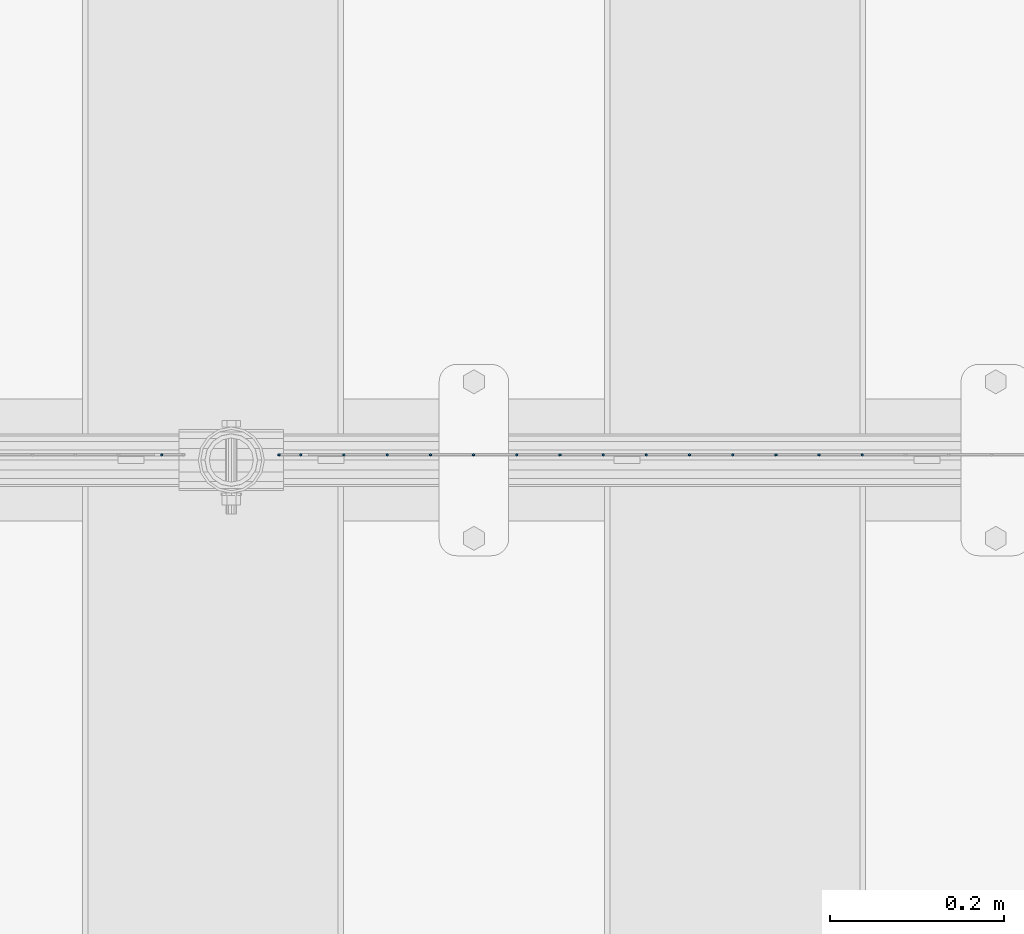
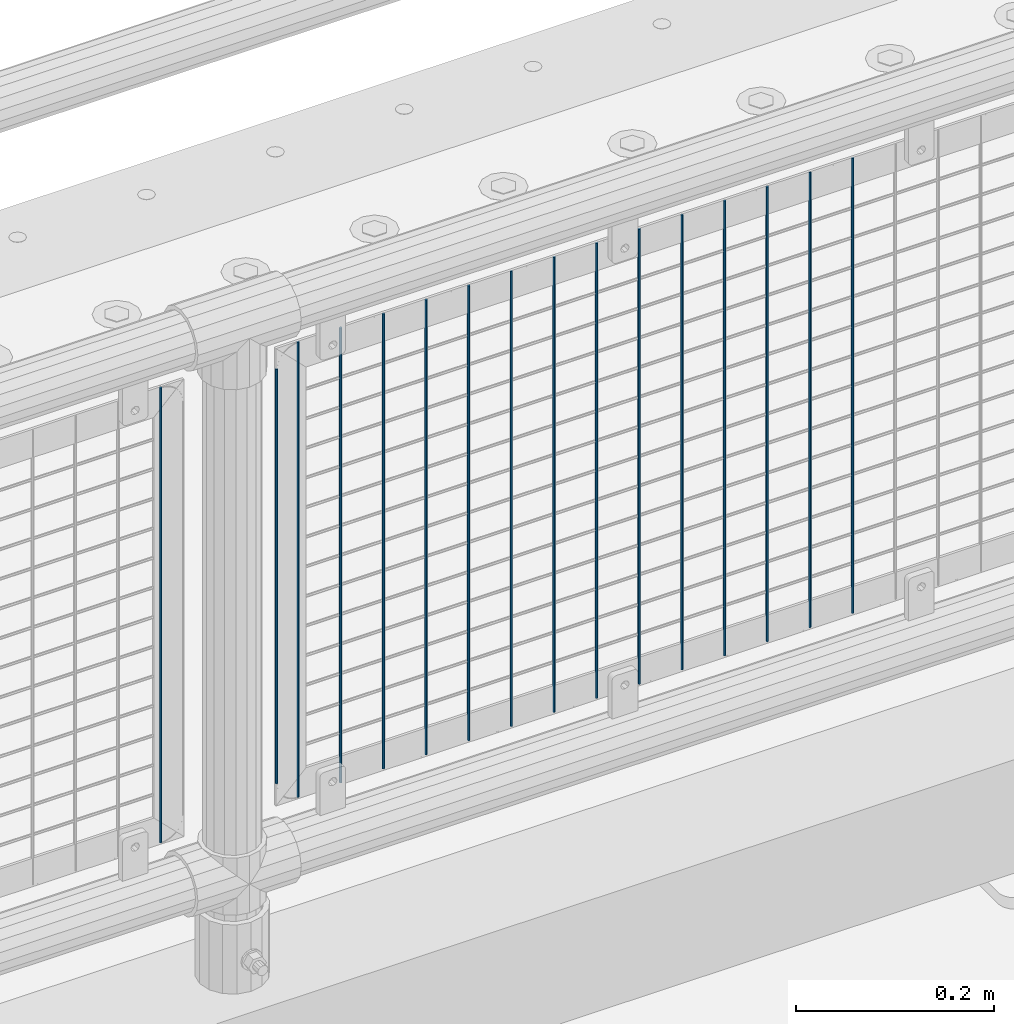
# One storey, part 72 of 247: 16 columns.
"""IFC2X3 building model written with IfcOpenShell, lengths in millimetres."""

from ifc_helpers import new_model, si_unit, frame, origin_with_axes, place, context, subcontext, project, spatial, faceted_brep, material, type_object, element, save


model = new_model("IFC2X3")

# Units and contexts
model_context = context("Model", 3, precision=1e-05, world=origin_with_axes())
body_context = subcontext(model_context, "Body", "Model", "MODEL_VIEW")
ifc_project = project(units=[si_unit("LENGTHUNIT", "METRE", prefix="MILLI"), si_unit("AREAUNIT", "SQUARE_METRE"), si_unit("VOLUMEUNIT", "CUBIC_METRE"), si_unit("MASSUNIT", "GRAM", prefix="KILO"), si_unit("TIMEUNIT", "SECOND"), si_unit("PLANEANGLEUNIT", "RADIAN"), si_unit("SOLIDANGLEUNIT", "STERADIAN"), si_unit("THERMODYNAMICTEMPERATUREUNIT", "DEGREE_CELSIUS"), si_unit("LUMINOUSINTENSITYUNIT", "LUMEN")], contexts=[model_context])

# Site, building, storey
site_placement = place(None, origin_with_axes())
site = spatial("IfcSite", under=ifc_project, at=site_placement, CompositionType="ELEMENT")
building_placement = place(site_placement, origin_with_axes())
building = spatial("IfcBuilding", under=site, at=building_placement, Name="Standard", CompositionType="ELEMENT")
storey_placement = place(building_placement, origin_with_axes())
storey = spatial("IfcBuildingStorey", under=building, at=storey_placement, Name="Undefined", CompositionType="ELEMENT", Elevation=0.0)

# Columns
ifc_material = material(Name="Misc_Undefined")
column_type = type_object("IfcColumnType", Name="D3", PredefinedType="NOTDEFINED")
for number, where, z_axis, x_axis in (
    (1, (2946.515, 7670.5, 353.02), (-1.0, 0.0, 0.0), (0.0, 0.0, 1.0)),
    (2, (2896.86, 7670.5, 353.02), (-1.0, 0.0, 0.0), (0.0, 0.0, 1.0)),
    (3, (2847.205, 7670.5, 353.02), (-1.0, 0.0, 0.0), (0.0, 0.0, 1.0)),
    (4, (2797.55, 7670.5, 353.02), (-1.0, 0.0, 0.0), (0.0, 0.0, 1.0)),
    (5, (2747.895, 7670.5, 353.02), (-1.0, 0.0, 0.0), (0.0, 0.0, 1.0)),
    (6, (2698.24, 7670.5, 353.02), (-1.0, 0.0, 0.0), (0.0, 0.0, 1.0)),
    (7, (2648.585, 7670.5, 353.02), (-1.0, 0.0, 0.0), (0.0, 0.0, 1.0)),
    (8, (2598.93, 7670.5, 353.02), (-1.0, 0.0, 0.0), (0.0, 0.0, 1.0)),
    (9, (2549.275, 7670.5, 353.02), (-1.0, 0.0, 0.0), (0.0, 0.0, 1.0)),
    (10, (2499.62, 7670.5, 353.02), (-1.0, 0.0, 0.0), (0.0, 0.0, 1.0)),
    (11, (2449.965, 7670.5, 353.02), (-1.0, 0.0, 0.0), (0.0, 0.0, 1.0)),
    (12, (2400.31034482759, 7670.5, 353.02), (-1.0, 0.0, 0.0), (0.0, 0.0, 1.0)),
    (13, (2350.65517241379, 7670.5, 353.02), (-0.999999999962839, 0.0, 8.62099999968473e-06), (8.62099999949798e-06, 0.0, 0.999999999962839)),
):
    element("IfcColumn", number, at=place(storey_placement, frame(where, z_axis=z_axis, x_axis=x_axis)), inside=storey, type_object=column_type, material=ifc_material, ObjectType="D3", context=body_context, shape_type="Brep", body=[
        faceted_brep([(1.81898940354586e-12, -1.5, -5.6843418860808e-14), (0.0, -0.75, -1.29903810567703), (560.0, -0.75, -1.29903810567703), (560.0, -1.5, 0.0), (0.0, 0.75, -1.29903810567703), (560.0, 0.75, -1.29903810567703), (1.81898940354586e-12, 1.5, -5.6843418860808e-14), (560.0, 1.5, 0.0), (0.0, 0.75, 1.29903810567703), (560.0, 0.75, 1.29903810567703), (0.0, -0.75, 1.29903810567703), (560.0, -0.75, 1.29903810567703)], [[[0, 1, 2, 3]], [[1, 4, 5, 2]], [[4, 6, 7, 5]], [[6, 8, 9, 7]], [[8, 10, 11, 9]], [[10, 0, 3, 11]], [[5, 7, 9, 11, 3, 2]], [[10, 8, 6, 4, 1, 0]]]),
    ])
column_placement = place(storey_placement, frame((2276.0, 7670.5, 378.02), z_axis=(-1.0, 0.0, 0.0), x_axis=(0.0, 0.0, 1.0)))
element("IfcColumn", 14, at=column_placement, inside=storey, type_object=column_type, material=ifc_material, ObjectType="D3", context=body_context, shape_type="Brep", body=[
    faceted_brep([(1.81898940354586e-12, -1.5, -5.6843418860808e-14), (0.0, -0.75, -1.29903810567703), (510.0, -0.75, -1.29903810567703), (510.0, -1.5, 0.0), (0.0, 0.75, -1.29903810567703), (510.0, 0.75, -1.29903810567703), (1.81898940354586e-12, 1.5, -5.6843418860808e-14), (510.0, 1.5, 0.0), (0.0, 0.75, 1.29903810567703), (510.0, 0.75, 1.29903810567703), (0.0, -0.75, 1.29903810567703), (510.0, -0.75, 1.29903810567703)], [[[0, 1, 2, 3]], [[1, 4, 5, 2]], [[4, 6, 7, 5]], [[6, 8, 9, 7]], [[8, 10, 11, 9]], [[10, 0, 3, 11]], [[5, 7, 9, 11, 3, 2]], [[10, 8, 6, 4, 1, 0]]]),
])
for number, where, z_axis, x_axis in (
    (15, (2301.0, 7670.5, 353.02), (-1.0, 0.0, 0.0), (0.0, 0.0, 1.0)),
    (16, (2140.995, 7670.5, 353.02), (-1.0, 0.0, 0.0), (0.0, 0.0, 1.0)),
):
    element("IfcColumn", number, at=place(storey_placement, frame(where, z_axis=z_axis, x_axis=x_axis)), inside=storey, type_object=column_type, material=ifc_material, ObjectType="D3", context=body_context, shape_type="Brep", body=[
        faceted_brep([(1.81898940354586e-12, -1.5, -5.6843418860808e-14), (0.0, -0.75, -1.29903810567703), (560.0, -0.75, -1.29903810567703), (560.0, -1.5, 0.0), (0.0, 0.75, -1.29903810567703), (560.0, 0.75, -1.29903810567703), (1.81898940354586e-12, 1.5, -5.6843418860808e-14), (560.0, 1.5, 0.0), (0.0, 0.75, 1.29903810567703), (560.0, 0.75, 1.29903810567703), (0.0, -0.75, 1.29903810567703), (560.0, -0.75, 1.29903810567703)], [[[0, 1, 2, 3]], [[1, 4, 5, 2]], [[4, 6, 7, 5]], [[6, 8, 9, 7]], [[8, 10, 11, 9]], [[10, 0, 3, 11]], [[5, 7, 9, 11, 3, 2]], [[10, 8, 6, 4, 1, 0]]]),
    ])

save(model, "model.ifc")
